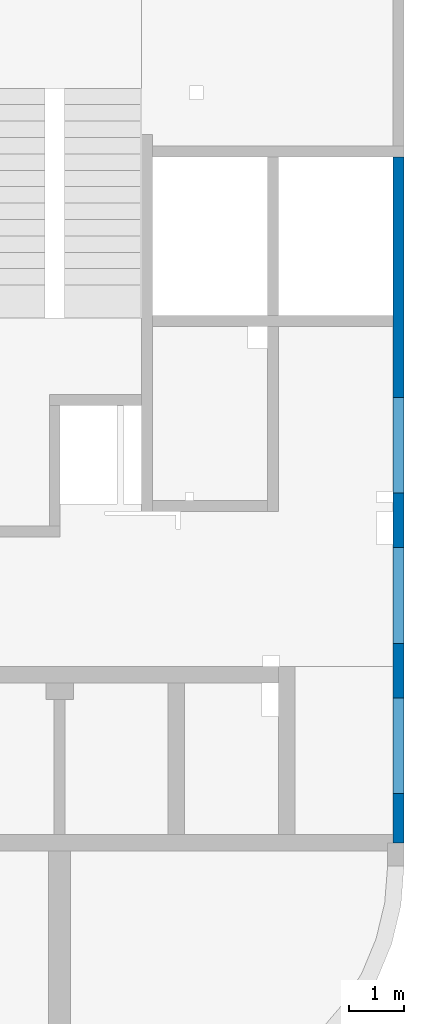
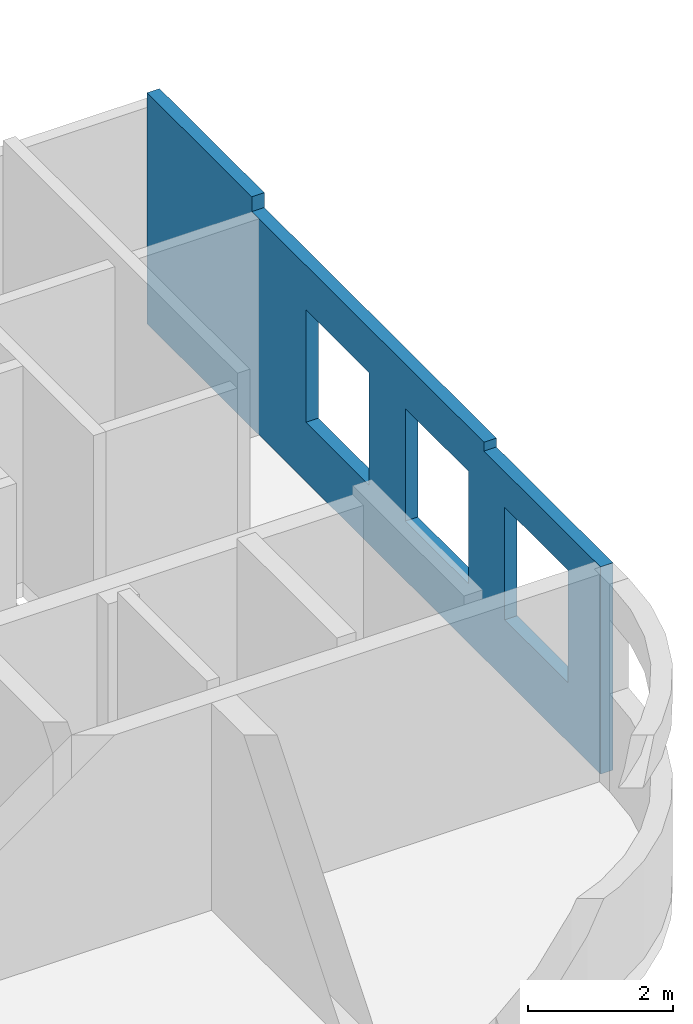
# One storey, part 10 of 10: 1 wall, 6 openings.
"""IFC4 building model written with IfcOpenShell, lengths in millimetres."""

from ifc_helpers import new_model, entity, si_unit, converted_unit, derived_unit, direction, frame, origin, place, context, subcontext, project, spatial, indexed_curve, outline, extrude, polygons, material, type_object, element, save


model = new_model("IFC4")

# Units and contexts
model_context = context("Model", 3, precision=0.01, world=origin(), true_north=direction((6.12303176911189e-17, 1.0)))
plan_context = context("Plan", 3, precision=0.01, world=origin(), true_north=direction((6.12303176911189e-17, 1.0)))
body_context = subcontext(model_context, "Body", "Model", "MODEL_VIEW")
ifc_project = project(units=[si_unit("LENGTHUNIT", "METRE", prefix="MILLI"), si_unit("AREAUNIT", "SQUARE_METRE"), si_unit("VOLUMEUNIT", "CUBIC_METRE"), converted_unit("PLANEANGLEUNIT", "DEGREE", entity("IfcRatioMeasure", 0.0174532925199433), si_unit("PLANEANGLEUNIT", "RADIAN"), dimensions=[0, 0, 0, 0, 0, 0, 0]), si_unit("MASSUNIT", "GRAM", prefix="KILO"), derived_unit("MASSDENSITYUNIT", [(si_unit("MASSUNIT", "GRAM", prefix="KILO"), 1), (si_unit("LENGTHUNIT", "METRE"), -3)]), derived_unit("MOMENTOFINERTIAUNIT", [(si_unit("LENGTHUNIT", "METRE"), 4)]), si_unit("TIMEUNIT", "SECOND"), si_unit("FREQUENCYUNIT", "HERTZ"), si_unit("THERMODYNAMICTEMPERATUREUNIT", "DEGREE_CELSIUS"), derived_unit("THERMALTRANSMITTANCEUNIT", [(si_unit("MASSUNIT", "GRAM", prefix="KILO"), 1), (si_unit("THERMODYNAMICTEMPERATUREUNIT", "KELVIN"), -1), (si_unit("TIMEUNIT", "SECOND"), -3)]), derived_unit("VOLUMETRICFLOWRATEUNIT", [(si_unit("LENGTHUNIT", "METRE"), 3), (si_unit("TIMEUNIT", "SECOND"), -1)]), derived_unit("MASSFLOWRATEUNIT", [(si_unit("MASSUNIT", "GRAM", prefix="KILO"), 1), (si_unit("TIMEUNIT", "SECOND"), -1)]), derived_unit("ROTATIONALFREQUENCYUNIT", [(si_unit("TIMEUNIT", "SECOND"), -1)]), si_unit("ELECTRICCURRENTUNIT", "AMPERE"), si_unit("ELECTRICVOLTAGEUNIT", "VOLT"), si_unit("POWERUNIT", "WATT"), si_unit("FORCEUNIT", "NEWTON", prefix="KILO"), si_unit("ILLUMINANCEUNIT", "LUX"), si_unit("LUMINOUSFLUXUNIT", "LUMEN"), si_unit("LUMINOUSINTENSITYUNIT", "CANDELA"), derived_unit("USERDEFINED", [(si_unit("MASSUNIT", "GRAM", prefix="KILO"), -1), (si_unit("LENGTHUNIT", "METRE"), -2), (si_unit("TIMEUNIT", "SECOND"), 3), (si_unit("LUMINOUSFLUXUNIT", "LUMEN"), 1)]), derived_unit("LINEARVELOCITYUNIT", [(si_unit("LENGTHUNIT", "METRE"), 1), (si_unit("TIMEUNIT", "SECOND"), -1)]), si_unit("PRESSUREUNIT", "PASCAL"), derived_unit("USERDEFINED", [(si_unit("LENGTHUNIT", "METRE"), -2), (si_unit("MASSUNIT", "GRAM", prefix="KILO"), 1), (si_unit("TIMEUNIT", "SECOND"), -2)]), derived_unit("LINEARFORCEUNIT", [(si_unit("MASSUNIT", "GRAM", prefix="KILO"), 1), (si_unit("LENGTHUNIT", "METRE"), 1), (si_unit("TIMEUNIT", "SECOND"), -2), (si_unit("LENGTHUNIT", "METRE"), -1)]), derived_unit("PLANARFORCEUNIT", [(si_unit("MASSUNIT", "GRAM", prefix="KILO"), 1), (si_unit("LENGTHUNIT", "METRE"), 1), (si_unit("TIMEUNIT", "SECOND"), -2), (si_unit("LENGTHUNIT", "METRE"), -2)])], contexts=[model_context, plan_context])

# Site, building, storey
site_placement = place(None, origin())
site = spatial("IfcSite", under=ifc_project, at=site_placement, CompositionType="ELEMENT")
building_placement = place(site_placement, origin())
building = spatial("IfcBuilding", under=site, at=building_placement, CompositionType="ELEMENT")
storey_placement = place(building_placement, frame((0.0, 0.0, 4200.0)))
storey = spatial("IfcBuildingStorey", under=building, at=storey_placement, Name="02", CompositionType="ELEMENT", Elevation=4200.0)

# Wall, openings
ifc_material = material()
wall_type = type_object("IfcWallType", Name=":ADSK_ 25_200", PredefinedType="STANDARD")
wall_placement = place(storey_placement, frame((73470.0, 17370.0, -150.0), z_axis=(0.0, 0.0, 1.0), x_axis=(0.0, -1.0, 0.0)))
wall = element("IfcWall", 1, at=wall_placement, inside=storey, type_object=wall_type, material=ifc_material, Name=":ADSK_ 25_200", ObjectType=":ADSK_ 25_200", PredefinedType="NOTDEFINED", context=body_context, shape_type="Tessellation", body=[
    polygons([(9894.9999999995, -99.9999999999996, 2900.0), (11644.9999999995, -99.9999999999944, 2900.0), (11644.9999999995, -99.9999999999944, 1000.00000000001), (9894.9999999995, -99.9999999999996, 1000.00000000001), (7144.9999999995, -99.9999999999991, 2900.0), (8894.9999999995, -99.9999999999939, 2900.0), (8894.9999999995, -99.9999999999939, 1000.00000000001), (7144.9999999995, -99.9999999999991, 1000.00000000001), (4394.99999999951, -100.000000000007, 2900.0), (6144.9999999995, -100.000000000002, 2900.0), (6144.9999999995, -100.000000000002, 1000.00000000001), (4394.99999999951, -100.000000000007, 1000.00000000001), (0.0, -99.9999999999945, 5.41433564649196e-13), (2899.9999999995, -99.9999999999945, 5.41433564649196e-13), (3099.9999999995, -99.9999999999939, 5.41433564649196e-13), (6119.99999999898, -99.9999999999935, 5.41433564649196e-13), (6319.99999999899, -99.999999999993, 5.41433564649196e-13), (6484.99999999899, -99.9999999999925, 5.41433564649196e-13), (7084.99999999899, -99.9999999999907, 5.41433564649196e-13), (12394.9999999994, -99.9999999999921, 5.41433564649196e-13), (12544.9999999994, -99.9999999999917, 5.41433564649196e-13), (12544.9999999994, -99.9999999999917, 3500.0), (12394.9999999994, -99.9999999999921, 3500.0), (9319.99999999947, -99.9999999999927, 3500.0), (9319.99999999947, -99.9999999999927, 3650.0), (3099.9999999995, -99.9999999999939, 3650.0), (2899.99999999951, -99.9999999999945, 3650.0), (2899.99999999951, -99.9999999999945, 3900.0), (0.0, -99.9999999999945, 3900.0), (11644.9999999995, 100.000000000315, 2900.0), (9894.99999999951, 100.000000000327, 2900.0), (9894.99999999951, 100.000000000327, 1000.00000000001), (11644.9999999995, 100.000000000315, 1000.00000000001), (8894.9999999995, 100.000000000324, 2900.0), (7144.9999999995, 100.000000000328, 2900.0), (7144.9999999995, 100.000000000328, 1000.00000000001), (8894.9999999995, 100.000000000324, 1000.00000000001), (6144.99999999951, 100.000000000325, 2900.0), (4394.99999999951, 100.00000000032, 2900.0), (4394.99999999951, 100.00000000032, 1000.00000000001), (6144.99999999951, 100.000000000325, 1000.00000000001), (12544.9999999994, 100.000000000006, 5.41433564649196e-13), (9319.99999999947, 100.000000000005, 5.41433564649196e-13), (2899.99999999951, 100.000000000003, 5.41433564649196e-13), (0.0, 100.000000000003, 5.41433564649196e-13), (0.0, 100.000000000003, 3650.0), (0.0, 100.000000000003, 3900.0), (2899.99999999951, 100.000000000003, 3900.0), (2899.99999999951, 100.000000000003, 3650.0), (9319.99999999947, 99.9999999999965, 3650.0), (9319.99999999947, 99.9999999999965, 3500.0), (12544.9999999994, 100.000000000006, 3500.0)], [[[13, 14, 15, 16, 17, 18, 19, 20, 21, 22, 23, 24, 25, 26, 27, 28, 29], [1, 2, 3, 4], [5, 6, 7, 8], [9, 10, 11, 12]], [[42, 43, 44, 45, 46, 47, 48, 49, 50, 51, 52], [30, 31, 32, 33], [34, 35, 36, 37], [38, 39, 40, 41]], [[21, 20, 19, 18, 17, 16, 15, 14, 13, 45, 44, 43, 42]], [[47, 29, 28, 48]], [[21, 42, 52, 22]], [[49, 27, 26, 25, 50]], [[27, 49, 48, 28]], [[31, 30, 2, 1]], [[31, 1, 4, 32]], [[32, 4, 3, 33]], [[2, 30, 33, 3]], [[35, 34, 6, 5]], [[35, 5, 8, 36]], [[36, 8, 7, 37]], [[6, 34, 37, 7]], [[39, 38, 10, 9]], [[39, 9, 12, 40]], [[40, 12, 11, 41]], [[10, 38, 41, 11]], [[51, 24, 23, 22, 52]], [[24, 51, 50, 25]], [[45, 13, 29, 47, 46]]], closed=True),
])
placement_1 = place(wall_placement, frame((17370.0, -73470.0, 150.0), z_axis=(0.0, 0.0, 1.0), x_axis=(0.0, 1.0, 0.0)))
element("IfcOpeningElement", 2, at=placement_1, cuts=wall, Name=":ADSK_ 25_200", PredefinedType="OPENING", context=body_context, shape_type="SweptSolid", body=[
    extrude(outline(indexed_curve([(-949.999999999993, -875.0), (949.999999999994, -875.0), (949.999999999994, 875.0), (-949.999999999993, 875.0), (-949.999999999993, -875.0)], self_intersect=False)), frame((73370.0, 12100.0, 1800.0), z_axis=(1.0, 0.0, 0.0), x_axis=(0.0, 0.0, -1.0)), (0.0, 0.0, 1.0), 200.000000000968),
])
placement_2 = place(wall_placement, origin())
element("IfcOpeningElement", 3, at=placement_2, cuts=wall, Name=":ADSK_ 25_200", PredefinedType="OPENING", context=body_context, shape_type="SweptSolid", body=[
    extrude(outline(indexed_curve([(-1449.99999999999, -874.999999999999), (1449.99999999999, -874.999999999999), (1449.99999999999, 875.0), (-1449.99999999999, 875.0), (-1449.99999999999, -874.999999999999)], self_intersect=False)), frame((10770.0, -100.0, 5350.0), z_axis=(0.0, 1.0, 0.0), x_axis=(0.0, 0.0, -1.0)), (0.0, 0.0, 1.0), 200.000000000968),
])
element("IfcOpeningElement", 4, at=placement_2, cuts=wall, Name=":ADSK_ 25_200", PredefinedType="OPENING", context=body_context, shape_type="SweptSolid", body=[
    extrude(outline(indexed_curve([(-874.999999999999, -1449.99999999999), (874.999999999999, -1449.99999999999), (874.999999999999, 1450.0), (-874.999999999999, 1450.0), (-874.999999999999, -1449.99999999999)], self_intersect=False)), frame((8020.0, -100.0, 5350.0), z_axis=(0.0, 1.0, 0.0), x_axis=(1.0, 0.0, 0.0)), (0.0, 0.0, 1.0), 200.000000000968),
])
element("IfcOpeningElement", 5, at=placement_2, cuts=wall, Name=":ADSK_ 25_200", PredefinedType="OPENING", context=body_context, shape_type="SweptSolid", body=[
    extrude(outline(indexed_curve([(-875.0, -1449.99999999999), (874.999999999998, -1449.99999999999), (874.999999999998, 1450.0), (-875.0, 1450.0), (-875.0, -1449.99999999999)], self_intersect=False)), frame((5270.0, -100.0, 5350.0), z_axis=(0.0, 1.0, 0.0), x_axis=(1.0, 0.0, 0.0)), (0.0, 0.0, 1.0), 200.000000000968),
])
element("IfcOpeningElement", 6, at=placement_1, cuts=wall, Name=":ADSK_ 25_200", PredefinedType="OPENING", context=body_context, shape_type="SweptSolid", body=[
    extrude(outline(indexed_curve([(-949.999999999993, -874.999999999999), (949.999999999994, -874.999999999999), (949.999999999994, 875.0), (-949.999999999993, 875.0), (-949.999999999993, -874.999999999999)], self_intersect=False)), frame((73370.0, 9350.0, 1800.0), z_axis=(1.0, 0.0, 0.0), x_axis=(0.0, 0.0, -1.0)), (0.0, 0.0, 1.0), 200.000000000968),
])
element("IfcOpeningElement", 7, at=placement_1, cuts=wall, Name=":ADSK_ 25_200", PredefinedType="OPENING", context=body_context, shape_type="SweptSolid", body=[
    extrude(outline(indexed_curve([(-949.999999999993, -875.0), (949.999999999994, -875.0), (949.999999999994, 874.999999999999), (-949.999999999993, 874.999999999999), (-949.999999999993, -875.0)], self_intersect=False)), frame((73370.0, 6600.0, 1800.0), z_axis=(1.0, 0.0, 0.0), x_axis=(0.0, 0.0, -1.0)), (0.0, 0.0, 1.0), 200.000000000968),
])

save(model, "model.ifc")
